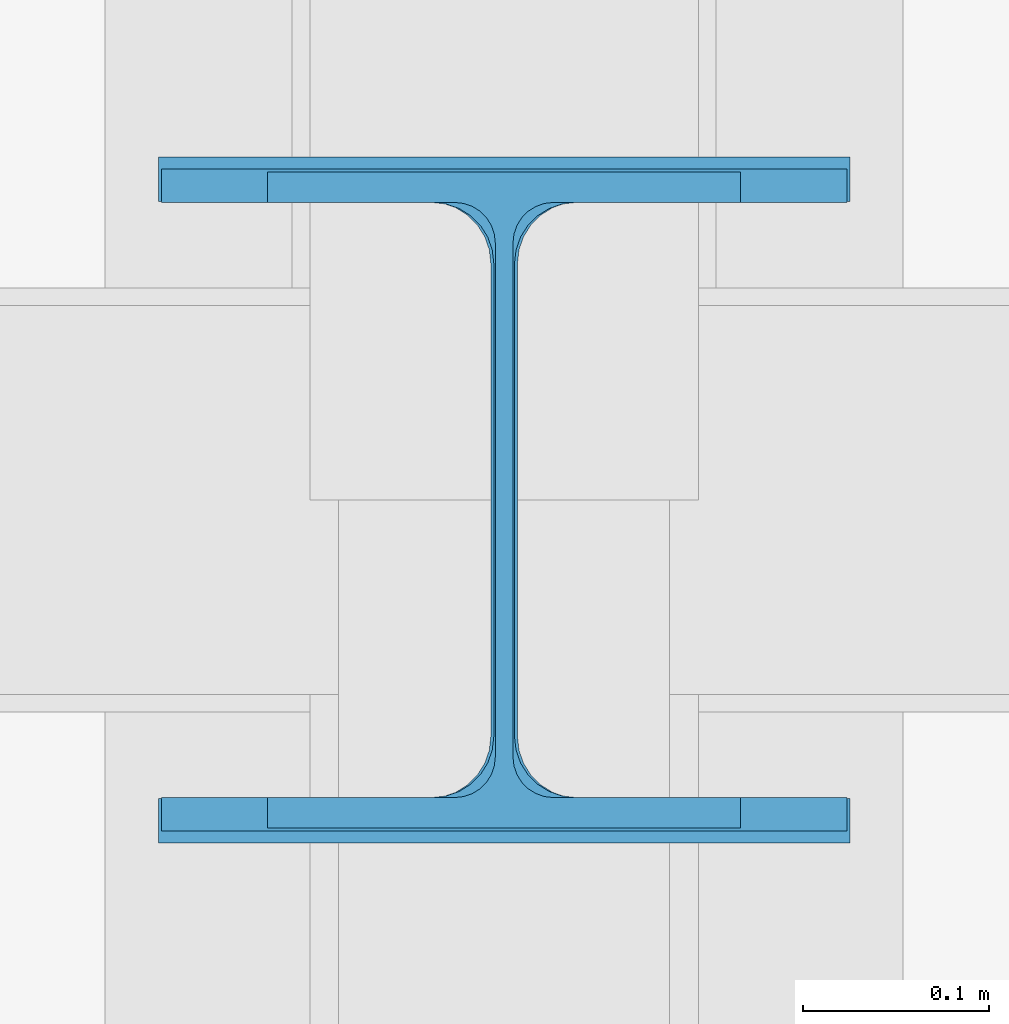
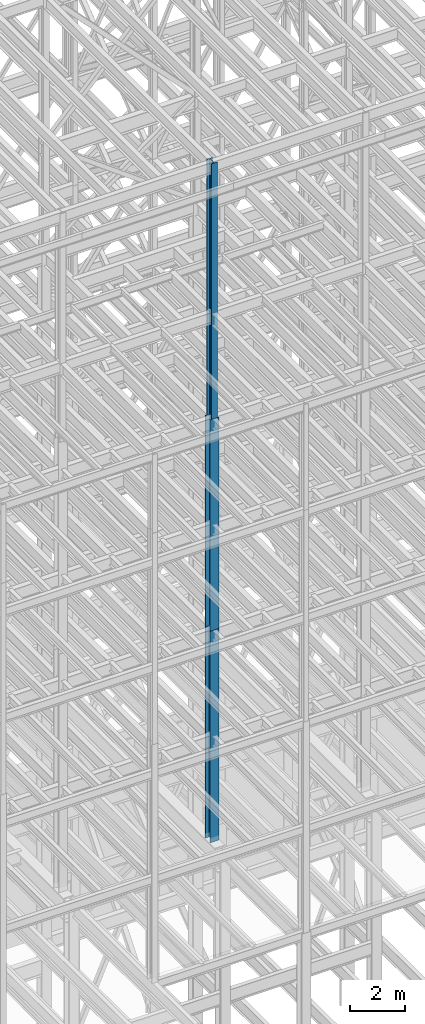
# One storey, part 32 of 150: 3 columns.
"""IFC2X3 building model written with IfcOpenShell, lengths in millimetres."""

from ifc_helpers import new_model, si_unit, frame, origin_with_axes, origin_2d_with_axis, place, context, subcontext, project, spatial, i_section, extrude, material, type_object, element, save


model = new_model("IFC2X3")

# Units and contexts
model_context = context("Model", 3, precision=1e-05, world=origin_with_axes())
body_context = subcontext(model_context, "Body", "Model", "MODEL_VIEW")
ifc_project = project(units=[si_unit("LENGTHUNIT", "METRE", prefix="MILLI"), si_unit("AREAUNIT", "SQUARE_METRE"), si_unit("VOLUMEUNIT", "CUBIC_METRE"), si_unit("MASSUNIT", "GRAM", prefix="KILO"), si_unit("TIMEUNIT", "SECOND"), si_unit("PLANEANGLEUNIT", "RADIAN"), si_unit("SOLIDANGLEUNIT", "STERADIAN"), si_unit("THERMODYNAMICTEMPERATUREUNIT", "DEGREE_CELSIUS"), si_unit("LUMINOUSINTENSITYUNIT", "LUMEN")], contexts=[model_context])

# Site, building, storey
site_placement = place(None, origin_with_axes())
site = spatial("IfcSite", under=ifc_project, at=site_placement, CompositionType="ELEMENT")
building_placement = place(site_placement, origin_with_axes())
building = spatial("IfcBuilding", under=site, at=building_placement, Name="Undefined", CompositionType="ELEMENT")
storey_placement = place(building_placement, origin_with_axes())
storey = spatial("IfcBuildingStorey", under=building, at=storey_placement, Name="Undefined", CompositionType="ELEMENT", Elevation=0.0)

# Columns
ifc_material = material(Name="STEEL/A992")
column_type_1 = type_object("IfcColumnType", Name="W14X61", PredefinedType="NOTDEFINED")
column_1_placement = place(storey_placement, frame((50190.4, 10185.4, 54483.0), z_axis=(0.0, 0.0, 1.0), x_axis=(1.0, 0.0, 0.0)))
element("IfcColumn", 1, at=column_1_placement, inside=storey, type_object=column_type_1, material=ifc_material, Name="COLUMN", ObjectType="W14X61", context=body_context, shape_type="SweptSolid", body=[
    extrude(i_section(OverallWidth=254.0, OverallDepth=352.425, WebThickness=9.5249, FlangeThickness=16.383, FilletRadius=21.717, at=origin_2d_with_axis()), frame((0.0, 0.0, 11430.0), z_axis=(0.0, 0.0, -1.0), x_axis=(-1.0, 0.0, 0.0)), (0.0, 0.0, 1.0), 11430.0),
])
column_type_2 = type_object("IfcColumnType", Name="W14X90", PredefinedType="NOTDEFINED")
column_2_placement = place(storey_placement, frame((50190.4, 10185.4, 45034.2009448801), z_axis=(0.0, 0.0, 1.0), x_axis=(1.0, 0.0, 0.0)))
element("IfcColumn", 2, at=column_2_placement, inside=storey, type_object=column_type_2, material=ifc_material, Name="COLUMN", ObjectType="W14X90", context=body_context, shape_type="SweptSolid", body=[
    extrude(i_section(OverallWidth=368.3, OverallDepth=355.6, WebThickness=11.1125, FlangeThickness=18.034, FilletRadius=32.7659, at=origin_2d_with_axis()), frame((0.0, 0.0, 9448.79905511992), z_axis=(0.0, 0.0, -1.0), x_axis=(-1.0, 0.0, 0.0)), (0.0, 0.0, 1.0), 9448.79905511991),
])
column_type_3 = type_object("IfcColumnType", Name="W14X120", PredefinedType="NOTDEFINED")
column_3_placement = place(storey_placement, frame((50190.4, 10185.4, 35585.4), z_axis=(0.0, 0.0, 1.0), x_axis=(1.0, 0.0, 0.0)))
element("IfcColumn", 3, at=column_3_placement, inside=storey, type_object=column_type_3, material=ifc_material, Name="COLUMN", ObjectType="W14X120", context=body_context, shape_type="SweptSolid", body=[
    extrude(i_section(OverallWidth=371.475, OverallDepth=368.3, WebThickness=14.2875, FlangeThickness=23.876, FilletRadius=33.274, at=origin_2d_with_axis()), frame((0.0, 0.0, 9448.8009448801), z_axis=(0.0, 0.0, -1.0), x_axis=(-1.0, 0.0, 0.0)), (0.0, 0.0, 1.0), 9448.8009448801),
])

save(model, "model.ifc")
